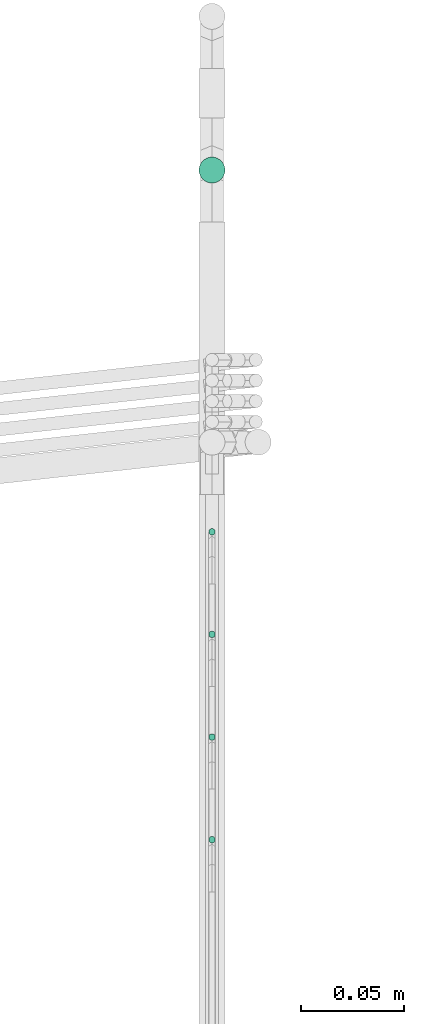
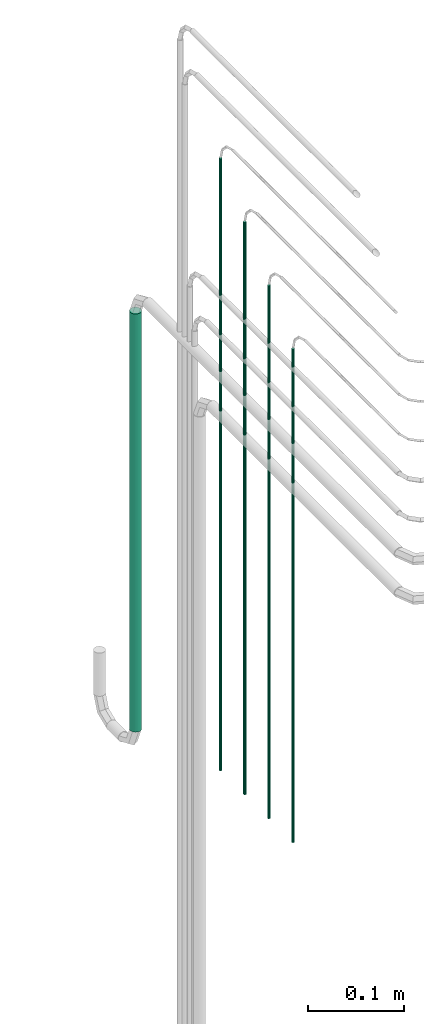
# One storey, part 21 of 45: 5 flow segments.
"""IFC2X3 building model written with IfcOpenShell, lengths in millimetres."""

from ifc_helpers import new_model, entity, si_unit, converted_unit, derived_unit, direction, frame, origin, origin_2d_with_axis, place, context, subcontext, project, spatial, circle, extrude, type_object, element, save


model = new_model("IFC2X3")

# Units and contexts
model_context = context("Model", 3, precision=0.01, world=origin(), true_north=direction((6.12303176911189e-17, 1.0)))
body_context = subcontext(model_context, "Body", "Model", "MODEL_VIEW")
ifc_project = project(units=[si_unit("LENGTHUNIT", "METRE", prefix="MILLI"), si_unit("AREAUNIT", "SQUARE_METRE"), si_unit("VOLUMEUNIT", "CUBIC_METRE"), converted_unit("PLANEANGLEUNIT", "DEGREE", entity("IfcRatioMeasure", 0.0174532925199433), si_unit("PLANEANGLEUNIT", "RADIAN"), dimensions=[0, 0, 0, 0, 0, 0, 0]), si_unit("MASSUNIT", "GRAM", prefix="KILO"), derived_unit("MASSDENSITYUNIT", [(si_unit("MASSUNIT", "GRAM", prefix="KILO"), 1), (si_unit("LENGTHUNIT", "METRE"), -3)]), derived_unit("MOMENTOFINERTIAUNIT", [(si_unit("LENGTHUNIT", "METRE"), 4)]), si_unit("TIMEUNIT", "SECOND"), si_unit("FREQUENCYUNIT", "HERTZ"), si_unit("THERMODYNAMICTEMPERATUREUNIT", "DEGREE_CELSIUS"), derived_unit("THERMALTRANSMITTANCEUNIT", [(si_unit("MASSUNIT", "GRAM", prefix="KILO"), 1), (si_unit("THERMODYNAMICTEMPERATUREUNIT", "KELVIN"), -1), (si_unit("TIMEUNIT", "SECOND"), -3)]), derived_unit("VOLUMETRICFLOWRATEUNIT", [(si_unit("LENGTHUNIT", "METRE"), 3), (si_unit("TIMEUNIT", "SECOND"), -1)]), derived_unit("MASSFLOWRATEUNIT", [(si_unit("MASSUNIT", "GRAM", prefix="KILO"), 1), (si_unit("TIMEUNIT", "SECOND"), -1)]), derived_unit("ROTATIONALFREQUENCYUNIT", [(si_unit("TIMEUNIT", "SECOND"), -1)]), si_unit("ELECTRICCURRENTUNIT", "AMPERE"), si_unit("ELECTRICVOLTAGEUNIT", "VOLT"), si_unit("POWERUNIT", "WATT"), si_unit("FORCEUNIT", "NEWTON", prefix="KILO"), si_unit("ILLUMINANCEUNIT", "LUX"), si_unit("LUMINOUSFLUXUNIT", "LUMEN"), si_unit("LUMINOUSINTENSITYUNIT", "CANDELA"), derived_unit("USERDEFINED", [(si_unit("MASSUNIT", "GRAM", prefix="KILO"), -1), (si_unit("LENGTHUNIT", "METRE"), -2), (si_unit("TIMEUNIT", "SECOND"), 3), (si_unit("LUMINOUSFLUXUNIT", "LUMEN"), 1)]), derived_unit("LINEARVELOCITYUNIT", [(si_unit("LENGTHUNIT", "METRE"), 1), (si_unit("TIMEUNIT", "SECOND"), -1)]), si_unit("PRESSUREUNIT", "PASCAL"), derived_unit("USERDEFINED", [(si_unit("LENGTHUNIT", "METRE"), -2), (si_unit("MASSUNIT", "GRAM", prefix="KILO"), 1), (si_unit("TIMEUNIT", "SECOND"), -2)]), derived_unit("LINEARFORCEUNIT", [(si_unit("MASSUNIT", "GRAM", prefix="KILO"), 1), (si_unit("LENGTHUNIT", "METRE"), 1), (si_unit("TIMEUNIT", "SECOND"), -2), (si_unit("LENGTHUNIT", "METRE"), -1)]), derived_unit("PLANARFORCEUNIT", [(si_unit("MASSUNIT", "GRAM", prefix="KILO"), 1), (si_unit("LENGTHUNIT", "METRE"), 1), (si_unit("TIMEUNIT", "SECOND"), -2), (si_unit("LENGTHUNIT", "METRE"), -2)])], contexts=[model_context])

# Site, building, storey
site_placement = place(None, frame((-24836.06, 8968.75, 0.0)))
site = spatial("IfcSite", under=ifc_project, at=site_placement, CompositionType="ELEMENT")
building_placement = place(site_placement, origin())
building = spatial("IfcBuilding", under=site, at=building_placement, CompositionType="ELEMENT")
storey_placement = place(building_placement, frame((0.0, 0.0, -4200.0)))
storey = spatial("IfcBuildingStorey", under=building, at=storey_placement, CompositionType="ELEMENT", Elevation=-4200.0)

# Flow segments
pipe_segment_type = type_object("IfcPipeSegmentType", PredefinedType="NOTDEFINED")
flow_segment_1_placement = place(storey_placement, frame((80742.57, -7246.07, 1500.0)))
element("IfcFlowSegment", 1, at=flow_segment_1_placement, inside=storey, type_object=pipe_segment_type, context=body_context, shape_type="SweptSolid", body=[
    extrude(circle(Radius=1.59, at=origin_2d_with_axis()), frame((3.19, 3.19, 0.0)), (0.0, 0.0, 1.0), 724.599999999991),
])
flow_segment_2_placement = place(storey_placement, frame((80742.57, -7296.07, 1500.0)))
element("IfcFlowSegment", 2, at=flow_segment_2_placement, inside=storey, type_object=pipe_segment_type, context=body_context, shape_type="SweptSolid", body=[
    extrude(circle(Radius=1.59, at=origin_2d_with_axis()), frame((3.19, 3.19, 0.0)), (0.0, 0.0, 1.0), 674.599999999996),
])
flow_segment_3_placement = place(storey_placement, frame((80742.57, -7346.07, 1500.0)))
element("IfcFlowSegment", 3, at=flow_segment_3_placement, inside=storey, type_object=pipe_segment_type, context=body_context, shape_type="SweptSolid", body=[
    extrude(circle(Radius=1.59, at=origin_2d_with_axis()), frame((3.19, 3.19, 0.0)), (0.0, 0.0, 1.0), 624.599999999995),
])
flow_segment_4_placement = place(storey_placement, frame((80737.81, -7024.5, 1445.4)))
element("IfcFlowSegment", 4, at=flow_segment_4_placement, inside=storey, type_object=pipe_segment_type, context=body_context, shape_type="SweptSolid", body=[
    extrude(circle(Radius=6.35, at=origin_2d_with_axis()), frame((7.95, 7.95, 0.0)), (0.0, 0.0, 1.0), 529.199999999996),
])
flow_segment_5_placement = place(storey_placement, frame((80742.57, -7196.07, 1500.0)))
element("IfcFlowSegment", 5, at=flow_segment_5_placement, inside=storey, type_object=pipe_segment_type, context=body_context, shape_type="SweptSolid", body=[
    extrude(circle(Radius=1.59, at=origin_2d_with_axis()), frame((3.19, 3.19, 0.0), z_axis=(0.0, 0.0, 1.0), x_axis=(-1.0, 0.0, 0.0)), (0.0, 0.0, 1.0), 774.59999999999),
])

save(model, "model.ifc")
